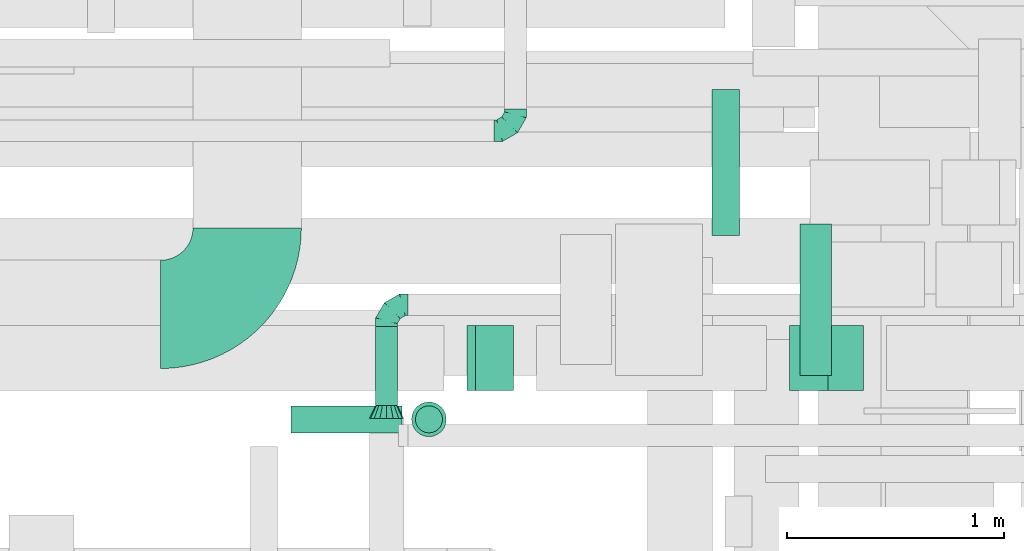
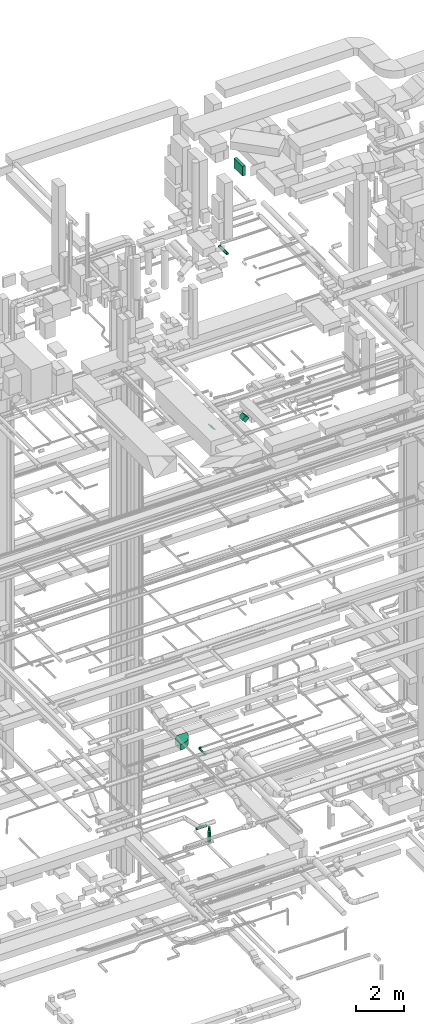
# One storey, part 150 of 337: 8 flow segments, 4 flow fittings.
"""IFC2X3 building model written with IfcOpenShell, lengths in millimetres."""

from ifc_helpers import new_model, entity, si_unit, converted_unit, derived_unit, direction, frame, frame_2d, origin, origin_2d_with_axis, place, context, subcontext, project, spatial, polyline, circle_curve, parameter, trimmed, segment, composite_curve, rectangle, circle, outline, extrude, faceted_brep, source, transform, mapped, material, type_object, type_shapes, element, save


model = new_model("IFC2X3")

# Units and contexts
model_context = context("Model", 3, precision=0.01, world=origin(), true_north=direction((6.12303176911189e-17, 1.0)))
body_context = subcontext(model_context, "Body", "Model", "MODEL_VIEW")
ifc_project = project(units=[si_unit("LENGTHUNIT", "METRE", prefix="MILLI"), si_unit("AREAUNIT", "SQUARE_METRE"), si_unit("VOLUMEUNIT", "CUBIC_METRE"), converted_unit("PLANEANGLEUNIT", "DEGREE", entity("IfcRatioMeasure", 0.0174532925199433), si_unit("PLANEANGLEUNIT", "RADIAN"), dimensions=[0, 0, 0, 0, 0, 0, 0]), si_unit("MASSUNIT", "GRAM", prefix="KILO"), derived_unit("MASSDENSITYUNIT", [(si_unit("MASSUNIT", "GRAM", prefix="KILO"), 1), (si_unit("LENGTHUNIT", "METRE"), -3)]), derived_unit("MOMENTOFINERTIAUNIT", [(si_unit("LENGTHUNIT", "METRE"), 4)]), si_unit("TIMEUNIT", "SECOND"), si_unit("FREQUENCYUNIT", "HERTZ"), si_unit("THERMODYNAMICTEMPERATUREUNIT", "DEGREE_CELSIUS"), derived_unit("THERMALTRANSMITTANCEUNIT", [(si_unit("MASSUNIT", "GRAM", prefix="KILO"), 1), (si_unit("THERMODYNAMICTEMPERATUREUNIT", "KELVIN"), -1), (si_unit("TIMEUNIT", "SECOND"), -3)]), derived_unit("VOLUMETRICFLOWRATEUNIT", [(si_unit("LENGTHUNIT", "METRE"), 3), (si_unit("TIMEUNIT", "SECOND"), -1)]), derived_unit("MASSFLOWRATEUNIT", [(si_unit("MASSUNIT", "GRAM", prefix="KILO"), 1), (si_unit("TIMEUNIT", "SECOND"), -1)]), derived_unit("ROTATIONALFREQUENCYUNIT", [(si_unit("TIMEUNIT", "SECOND"), -1)]), si_unit("ELECTRICCURRENTUNIT", "AMPERE"), si_unit("ELECTRICVOLTAGEUNIT", "VOLT"), si_unit("POWERUNIT", "WATT"), si_unit("FORCEUNIT", "NEWTON", prefix="KILO"), si_unit("ILLUMINANCEUNIT", "LUX"), si_unit("LUMINOUSFLUXUNIT", "LUMEN"), si_unit("LUMINOUSINTENSITYUNIT", "CANDELA"), derived_unit("USERDEFINED", [(si_unit("MASSUNIT", "GRAM", prefix="KILO"), -1), (si_unit("LENGTHUNIT", "METRE"), -2), (si_unit("TIMEUNIT", "SECOND"), 3), (si_unit("LUMINOUSFLUXUNIT", "LUMEN"), 1)]), derived_unit("LINEARVELOCITYUNIT", [(si_unit("LENGTHUNIT", "METRE"), 1), (si_unit("TIMEUNIT", "SECOND"), -1)]), si_unit("PRESSUREUNIT", "PASCAL"), derived_unit("USERDEFINED", [(si_unit("LENGTHUNIT", "METRE"), -2), (si_unit("MASSUNIT", "GRAM", prefix="KILO"), 1), (si_unit("TIMEUNIT", "SECOND"), -2)]), derived_unit("LINEARFORCEUNIT", [(si_unit("MASSUNIT", "GRAM", prefix="KILO"), 1), (si_unit("LENGTHUNIT", "METRE"), 1), (si_unit("TIMEUNIT", "SECOND"), -2), (si_unit("LENGTHUNIT", "METRE"), -1)]), derived_unit("PLANARFORCEUNIT", [(si_unit("MASSUNIT", "GRAM", prefix="KILO"), 1), (si_unit("LENGTHUNIT", "METRE"), 1), (si_unit("TIMEUNIT", "SECOND"), -2), (si_unit("LENGTHUNIT", "METRE"), -2)])], contexts=[model_context])

# Site, building, storey
site_placement = place(None, origin())
site = spatial("IfcSite", under=ifc_project, at=site_placement, CompositionType="ELEMENT")
building_placement = place(site_placement, origin())
building = spatial("IfcBuilding", under=site, at=building_placement, CompositionType="ELEMENT")
storey_placement = place(building_placement, origin())
storey = spatial("IfcBuildingStorey", under=building, at=storey_placement, CompositionType="ELEMENT", Elevation=0.0)

# Flow segments
duct_segment_type_1 = type_object("IfcDuctSegmentType", PredefinedType="NOTDEFINED")
flow_segment_1_placement = place(storey_placement, frame((36336.98, 14025.53, 18967.16)))
element("IfcFlowSegment", 1, at=flow_segment_1_placement, inside=storey, type_object=duct_segment_type_1, context=body_context, shape_type="SweptSolid", body=[
    extrude(rectangle(XDim=55.0252531694249, YDim=249.999999999998, at=origin_2d_with_axis()), frame((107.84, 0.0, 107.84), z_axis=(0.0, 1.0, 0.0), x_axis=(0.70710678118641, 0.0, 0.707106781186685)), (0.0, 0.0, 1.0), 299.999999999999),
])
flow_segment_2_placement = place(storey_placement, frame((37826.98, 14025.53, 18842.16)))
element("IfcFlowSegment", 2, at=flow_segment_2_placement, inside=storey, type_object=duct_segment_type_1, context=body_context, shape_type="SweptSolid", body=[
    extrude(rectangle(XDim=231.801948466083, YDim=250.000000000003, at=origin_2d_with_axis()), frame((170.34, 0.0, 170.34), z_axis=(0.0, 1.0, 0.0), x_axis=(0.707106781186515, 0.0, -0.70710678118658)), (0.0, 0.0, 1.0), 300.000000000001),
])
flow_segment_3_placement = place(storey_placement, frame((37873.99, 14094.6, 31400.0)))
element("IfcFlowSegment", 3, at=flow_segment_3_placement, inside=storey, type_object=duct_segment_type_1, context=body_context, shape_type="SweptSolid", body=[
    extrude(rectangle(XDim=146.045750909778, YDim=700.000000000001, at=origin_2d_with_axis()), frame((73.02, 350.0, 0.0), z_axis=(0.0, 0.0, 1.0), x_axis=(-1.0, 0.0, 0.0)), (0.0, 0.0, 1.0), 499.999999999999),
])
duct_segment_type_2 = type_object("IfcDuctSegmentType", PredefinedType="NOTDEFINED")
flow_segment_4_placement = place(storey_placement, frame((35524.64, 13828.01, -984.1)))
element("IfcFlowSegment", 4, at=flow_segment_4_placement, inside=storey, type_object=duct_segment_type_2, context=body_context, shape_type="SweptSolid", body=[
    extrude(circle(Radius=62.5, at=origin_2d_with_axis()), frame((0.0, 64.1, 64.1), z_axis=(1.0, 0.0, 0.0), x_axis=(0.0, -1.0, 0.0)), (0.0, 0.0, 1.0), 512.325703081815),
])
flow_segment_5_placement = place(storey_placement, frame((36097.87, 13828.01, -1205.34)))
element("IfcFlowSegment", 5, at=flow_segment_5_placement, inside=storey, type_object=duct_segment_type_2, context=body_context, shape_type="SweptSolid", body=[
    extrude(circle(Radius=62.5, at=origin_2d_with_axis()), frame((64.1, 64.1, 0.0), z_axis=(0.0, 0.0, 1.0), x_axis=(0.0, 1.0, 0.0)), (0.0, 0.0, 1.0), 160.338533839341),
])
flow_segment_6_placement = place(storey_placement, frame((36080.37, 13810.51, -1800.0)))
element("IfcFlowSegment", 6, at=flow_segment_6_placement, inside=storey, type_object=duct_segment_type_2, context=body_context, shape_type="SweptSolid", body=[
    extrude(circle(Radius=80.0, at=origin_2d_with_axis()), frame((81.6, 81.6, 0.0), z_axis=(0.0, 0.0, 1.0), x_axis=(-1.0, 0.0, 0.0)), (0.0, 0.0, 1.0), 529.361466160666),
])
flow_segment_7_placement = place(storey_placement, frame((35914.48, 13956.15, 2668.4)))
element("IfcFlowSegment", 7, at=flow_segment_7_placement, inside=storey, type_object=duct_segment_type_2, context=body_context, shape_type="SweptSolid", body=[
    extrude(circle(Radius=50.0, at=origin_2d_with_axis()), frame((51.6, 0.0, 51.6), z_axis=(0.0, 1.0, 0.0), x_axis=(1.0, 0.0, 0.0)), (0.0, 0.0, 1.0), 364.374999999984),
])
flow_segment_8_placement = place(storey_placement, frame((37468.11, 14740.09, 27105.9)))
element("IfcFlowSegment", 8, at=flow_segment_8_placement, inside=storey, type_object=duct_segment_type_2, context=body_context, shape_type="SweptSolid", body=[
    extrude(circle(Radius=62.5, at=origin_2d_with_axis()), frame((64.1, 0.0, 64.1), z_axis=(0.0, 1.0, 0.0), x_axis=(-1.0, 0.0, 0.0)), (0.0, 0.0, 1.0), 675.000000000026),
])

# Flow fittings
ifc_material = material()
duct_fitting_type_1 = type_object("IfcDuctFittingType", PredefinedType="NOTDEFINED", material=ifc_material)
shared_shape_1 = source(origin(), body_context, "Body", "Brep", [
    faceted_brep([(-100.0, 0.0, -50.0), (-100.0, -12.94, -48.3), (-100.0, -25.0, -43.3), (-100.0, -35.36, -35.36), (-100.0, -43.3, -25.0), (-100.0, -48.3, -12.94), (-100.0, -50.0, 0.0), (-100.0, -48.3, 12.94), (-100.0, -43.3, 25.0), (-100.0, -35.36, 35.36), (-100.0, -25.0, 43.3), (-100.0, -12.94, 48.3), (-100.0, 0.0, 50.0), (-100.0, 12.94, 48.3), (-100.0, 25.0, 43.3), (-100.0, 35.36, 35.36), (-100.0, 43.3, 25.0), (-100.0, 48.3, 12.94), (-100.0, 50.0, 0.0), (-100.0, 48.3, -12.94), (-100.0, 43.3, -25.0), (-100.0, 35.36, -35.36), (-100.0, 25.0, -43.3), (-100.0, 12.94, -48.3), (-76.67, 12.94, 48.3), (-79.9, 25.0, 43.3), (-73.21, 0.0, 50.0), (-82.68, 35.36, 35.36), (-86.15, 48.3, 12.94), (-86.6, 50.0, 0.0), (-84.81, 43.3, 25.0), (-84.81, 43.3, -25.0), (-82.68, 35.36, -35.36), (-86.15, 48.3, -12.94), (-76.67, 12.94, -48.3), (-73.21, 0.0, -50.0), (-79.9, 25.0, -43.3), (-69.74, -12.94, -48.3), (-66.51, -25.0, -43.3), (-63.73, -35.36, -35.36), (-61.6, -43.3, -25.0), (-60.26, -48.3, -12.94), (-59.81, -50.0, 0.0), (-60.26, -48.3, 12.94), (-61.6, -43.3, 25.0), (-63.73, -35.36, 35.36), (-66.51, -25.0, 43.3), (-69.74, -12.94, 48.3), (-36.27, 36.27, 48.3), (-45.1, 45.1, 43.3), (-26.79, 26.79, 50.0), (-52.68, 52.68, 35.36), (-58.49, 58.49, 25.0), (-62.15, 62.15, 12.94), (-63.4, 63.4, 0.0), (-62.15, 62.15, -12.94), (-58.49, 58.49, -25.0), (-52.68, 52.68, -35.36), (-36.27, 36.27, -48.3), (-26.79, 26.79, -50.0), (-45.1, 45.1, -43.3), (-17.32, 17.32, -48.3), (-8.49, 8.49, -43.3), (-0.91, 0.91, -35.36), (4.9, -4.9, -25.0), (8.56, -8.56, -12.94), (9.81, -9.81, 0.0), (8.56, -8.56, 12.94), (4.9, -4.9, 25.0), (-0.91, 0.91, 35.36), (-8.49, 8.49, 43.3), (-17.32, 17.32, 48.3), (-12.94, 76.67, 48.3), (-25.0, 79.9, 43.3), (0.0, 73.21, 50.0), (-35.36, 82.68, 35.36), (-43.3, 84.81, 25.0), (-48.3, 86.15, 12.94), (-50.0, 86.6, 0.0), (-48.3, 86.15, -12.94), (-43.3, 84.81, -25.0), (-35.36, 82.68, -35.36), (-12.94, 76.67, -48.3), (0.0, 73.21, -50.0), (-25.0, 79.9, -43.3), (12.94, 69.74, -48.3), (25.0, 66.51, -43.3), (35.36, 63.73, -35.36), (43.3, 61.6, -25.0), (48.3, 60.26, -12.94), (50.0, 59.81, 0.0), (48.3, 60.26, 12.94), (43.3, 61.6, 25.0), (35.36, 63.73, 35.36), (25.0, 66.51, 43.3), (12.94, 69.74, 48.3), (-12.94, 100.0, -48.3), (-25.0, 100.0, -43.3), (-35.36, 100.0, -35.36), (-43.3, 100.0, -25.0), (-48.3, 100.0, -12.94), (-50.0, 100.0, 0.0), (-48.3, 100.0, 12.94), (-43.3, 100.0, 25.0), (-35.36, 100.0, 35.36), (-25.0, 100.0, 43.3), (-12.94, 100.0, 48.3), (0.0, 100.0, 50.0), (12.94, 100.0, 48.3), (25.0, 100.0, 43.3), (35.36, 100.0, 35.36), (43.3, 100.0, 25.0), (48.3, 100.0, 12.94), (50.0, 100.0, 0.0), (48.3, 100.0, -12.94), (43.3, 100.0, -25.0), (35.36, 100.0, -35.36), (25.0, 100.0, -43.3), (12.94, 100.0, -48.3), (0.0, 100.0, -50.0)], [[[0, 1, 2, 3, 4, 5, 6, 7, 8, 9, 10, 11, 12, 13, 14, 15, 16, 17, 18, 19, 20, 21, 22, 23]], [[24, 25, 14, 13]], [[26, 24, 13, 12]], [[14, 25, 27, 15]], [[28, 29, 18, 17]], [[30, 28, 17, 16]], [[15, 27, 30, 16]], [[20, 31, 32, 21]], [[33, 31, 20, 19]], [[18, 29, 33, 19]], [[34, 35, 0, 23]], [[36, 34, 23, 22]], [[32, 36, 22, 21]], [[2, 1, 37, 38]], [[3, 2, 38, 39]], [[0, 35, 37, 1]], [[5, 4, 40, 41]], [[6, 5, 41, 42]], [[3, 39, 40, 4]], [[6, 42, 43, 7]], [[7, 43, 44, 8]], [[8, 44, 45, 9]], [[10, 46, 47, 11]], [[11, 47, 26, 12]], [[10, 9, 45, 46]], [[48, 49, 25, 24]], [[50, 48, 24, 26]], [[27, 25, 49, 51]], [[52, 53, 28, 30]], [[51, 52, 30, 27]], [[29, 28, 53, 54]], [[55, 56, 31, 33]], [[54, 55, 33, 29]], [[57, 32, 31, 56]], [[58, 59, 35, 34]], [[60, 58, 34, 36]], [[57, 60, 36, 32]], [[37, 35, 59, 61]], [[38, 37, 61, 62]], [[39, 38, 62, 63]], [[41, 40, 64, 65]], [[42, 41, 65, 66]], [[63, 64, 40, 39]], [[43, 42, 66, 67]], [[44, 43, 67, 68]], [[68, 69, 45, 44]], [[46, 45, 69, 70]], [[47, 46, 70, 71]], [[26, 47, 71, 50]], [[72, 73, 49, 48]], [[74, 72, 48, 50]], [[51, 49, 73, 75]], [[76, 77, 53, 52]], [[75, 76, 52, 51]], [[54, 53, 77, 78]], [[79, 80, 56, 55]], [[78, 79, 55, 54]], [[81, 57, 56, 80]], [[82, 83, 59, 58]], [[84, 82, 58, 60]], [[81, 84, 60, 57]], [[61, 59, 83, 85]], [[62, 61, 85, 86]], [[63, 62, 86, 87]], [[65, 64, 88, 89]], [[66, 65, 89, 90]], [[87, 88, 64, 63]], [[67, 66, 90, 91]], [[68, 67, 91, 92]], [[92, 93, 69, 68]], [[70, 69, 93, 94]], [[71, 70, 94, 95]], [[50, 71, 95, 74]], [[96, 97, 98, 99, 100, 101, 102, 103, 104, 105, 106, 107, 108, 109, 110, 111, 112, 113, 114, 115, 116, 117, 118, 119]], [[72, 74, 107, 106]], [[73, 72, 106, 105]], [[75, 73, 105, 104]], [[77, 76, 103, 102]], [[78, 77, 102, 101]], [[75, 104, 103, 76]], [[78, 101, 100, 79]], [[79, 100, 99, 80]], [[80, 99, 98, 81]], [[96, 119, 83, 82]], [[97, 96, 82, 84]], [[84, 81, 98, 97]], [[83, 119, 118, 85]], [[85, 118, 117, 86]], [[86, 117, 116, 87]], [[88, 115, 114, 89]], [[89, 114, 113, 90]], [[87, 116, 115, 88]], [[91, 90, 113, 112]], [[92, 91, 112, 111]], [[93, 92, 111, 110]], [[95, 94, 109, 108]], [[74, 95, 108, 107]], [[110, 109, 94, 93]]]),
])
type_shapes(duct_fitting_type_1, [shared_shape_1])
flow_fitting_1_placement = place(storey_placement, frame((35966.08, 14420.53, 2720.0), z_axis=(0.0, 0.0, 1.0), x_axis=(-1.0, 0.0, 0.0)))
element("IfcFlowFitting", 9, at=flow_fitting_1_placement, inside=storey, type_object=duct_fitting_type_1, material=ifc_material, context=body_context, shape_type="MappedRepresentation", body=[
    mapped(shared_shape_1, transform((0.0, 0.0, 0.0), scale=1.0)),
])
flow_fitting_2_placement = place(storey_placement, frame((36561.25, 15224.94, 3600.0)))
element("IfcFlowFitting", 10, at=flow_fitting_2_placement, inside=storey, type_object=duct_fitting_type_1, material=ifc_material, context=body_context, shape_type="MappedRepresentation", body=[
    mapped(shared_shape_1, transform((0.0, 0.0, 0.0), scale=1.0)),
])
duct_fitting_type_2 = type_object("IfcDuctFittingType", PredefinedType="NOTDEFINED", material=ifc_material)
shared_shape_2 = source(origin(), body_context, "Body", "Brep", [
    faceted_brep([(60.0, -46.19, 19.13), (60.0, -48.1, 9.57), (60.0, -50.0, 0.0), (60.0, -48.1, -9.57), (60.0, -46.19, -19.13), (60.0, -40.77, -27.24), (60.0, -35.36, -35.36), (60.0, -27.24, -40.77), (60.0, -19.13, -46.19), (60.0, -9.57, -48.1), (60.0, 0.0, -50.0), (60.0, 9.57, -48.1), (60.0, 19.13, -46.19), (60.0, 27.24, -40.77), (60.0, 35.36, -35.36), (60.0, 40.77, -27.24), (60.0, 46.19, -19.13), (60.0, 48.1, -9.57), (60.0, 50.0, 0.0), (60.0, 48.1, 9.57), (60.0, 46.19, 19.13), (60.0, 40.77, 27.24), (60.0, 35.36, 35.36), (60.0, 27.24, 40.77), (60.0, 19.13, 46.19), (60.0, 9.57, 48.1), (60.0, 0.0, 50.0), (60.0, -9.57, 48.1), (60.0, -19.13, 46.19), (60.0, -27.24, 40.77), (60.0, -35.36, 35.36), (60.0, -40.77, 27.24), (0.0, -80.0, 0.0), (0.0, -77.16, 14.27), (0.0, -73.91, 30.61), (0.0, -65.24, 43.59), (0.0, -56.57, 56.57), (0.0, -43.59, 65.24), (0.0, -30.61, 73.91), (0.0, -15.31, 76.96), (0.0, 0.0, 80.0), (0.0, 14.27, 77.16), (0.0, 30.61, 73.91), (0.0, 43.59, 65.24), (0.0, 56.57, 56.57), (0.0, 65.24, 43.59), (0.0, 73.91, 30.61), (0.0, 76.96, 15.31), (0.0, 80.0, 0.0), (0.0, 77.16, -14.27), (0.0, 73.91, -30.61), (0.0, 65.24, -43.59), (0.0, 56.57, -56.57), (0.0, 43.59, -65.24), (0.0, 30.61, -73.91), (0.0, 15.31, -76.96), (0.0, 0.0, -80.0), (0.0, -14.27, -77.16), (0.0, -30.61, -73.91), (0.0, -43.59, -65.24), (0.0, -56.57, -56.57), (0.0, -65.24, -43.59), (0.0, -73.91, -30.61), (0.0, -76.96, -15.31)], [[[0, 1, 2, 3, 4, 5, 6, 7, 8, 9, 10, 11, 12, 13, 14, 15, 16, 17, 18, 19, 20, 21, 22, 23, 24, 25, 26, 27, 28, 29, 30, 31]], [[32, 33, 34, 35, 36, 37, 38, 39, 40, 41, 42, 43, 44, 45, 46, 47, 48, 49, 50, 51, 52, 53, 54, 55, 56, 57, 58, 59, 60, 61, 62, 63]], [[42, 41, 40, 26, 25, 24]], [[43, 42, 24, 23, 22, 44]], [[20, 46, 45, 44, 22, 21]], [[18, 48, 47, 46, 20, 19]], [[34, 33, 32, 2, 1, 0]], [[35, 34, 0, 31, 30, 36]], [[28, 38, 37, 36, 30, 29]], [[26, 40, 39, 38, 28, 27]], [[58, 57, 56, 10, 9, 8]], [[59, 58, 8, 7, 6, 60]], [[4, 62, 61, 60, 6, 5]], [[2, 32, 63, 62, 4, 3]], [[50, 49, 48, 18, 17, 16]], [[51, 50, 16, 15, 14, 52]], [[12, 54, 53, 52, 14, 13]], [[10, 56, 55, 54, 12, 11]]]),
])
type_shapes(duct_fitting_type_2, [shared_shape_2])
flow_fitting_3_placement = place(storey_placement, frame((35966.08, 13896.15, 2720.0), z_axis=(0.0, 0.0, 1.0), x_axis=(0.0, 1.0, 0.0)))
element("IfcFlowFitting", 11, at=flow_fitting_3_placement, inside=storey, type_object=duct_fitting_type_2, material=ifc_material, context=body_context, shape_type="MappedRepresentation", body=[
    mapped(shared_shape_2, transform((0.0, 0.0, 0.0), scale=1.0)),
])
duct_fitting_type_3 = type_object("IfcDuctFittingType", PredefinedType="NOTDEFINED", material=ifc_material)
shared_shape_3 = source(origin(), body_context, "Body", "SweptSolid", [
    extrude(outline(composite_curve([segment(polyline([(-450.0, -200.0), (50.0, -200.0)]), True, "CONTINUOUS"), segment(trimmed(circle_curve(frame_2d((200.0, -200.0), x_axis=(0.0, 1.0)), 150.0), [parameter(0.0)], [parameter(90.0000000000001)], True, "PARAMETER"), False, "CONTINUOUS"), segment(polyline([(200.0, -50.0), (200.0, 450.0)]), True, "CONTINUOUS"), segment(trimmed(circle_curve(frame_2d((200.0, -200.0), x_axis=(0.0, 1.0)), 650.0), [parameter(0.0)], [parameter(90.0000000000001)], True, "PARAMETER"), True, "CONTINUOUS")], self_intersect=False)), frame((-200.0, 200.0, -150.0), z_axis=(0.0, 0.0, 1.0), x_axis=(-1.0, 0.0, 0.0)), (0.0, 0.0, 1.0), 300.0),
])
type_shapes(duct_fitting_type_3, [shared_shape_3])
flow_fitting_4_placement = place(storey_placement, frame((35322.98, 14376.58, 3300.0)))
element("IfcFlowFitting", 12, at=flow_fitting_4_placement, inside=storey, type_object=duct_fitting_type_3, material=ifc_material, context=body_context, shape_type="MappedRepresentation", body=[
    mapped(shared_shape_3, transform((0.0, 0.0, 0.0), scale=1.0)),
])

save(model, "model.ifc")
